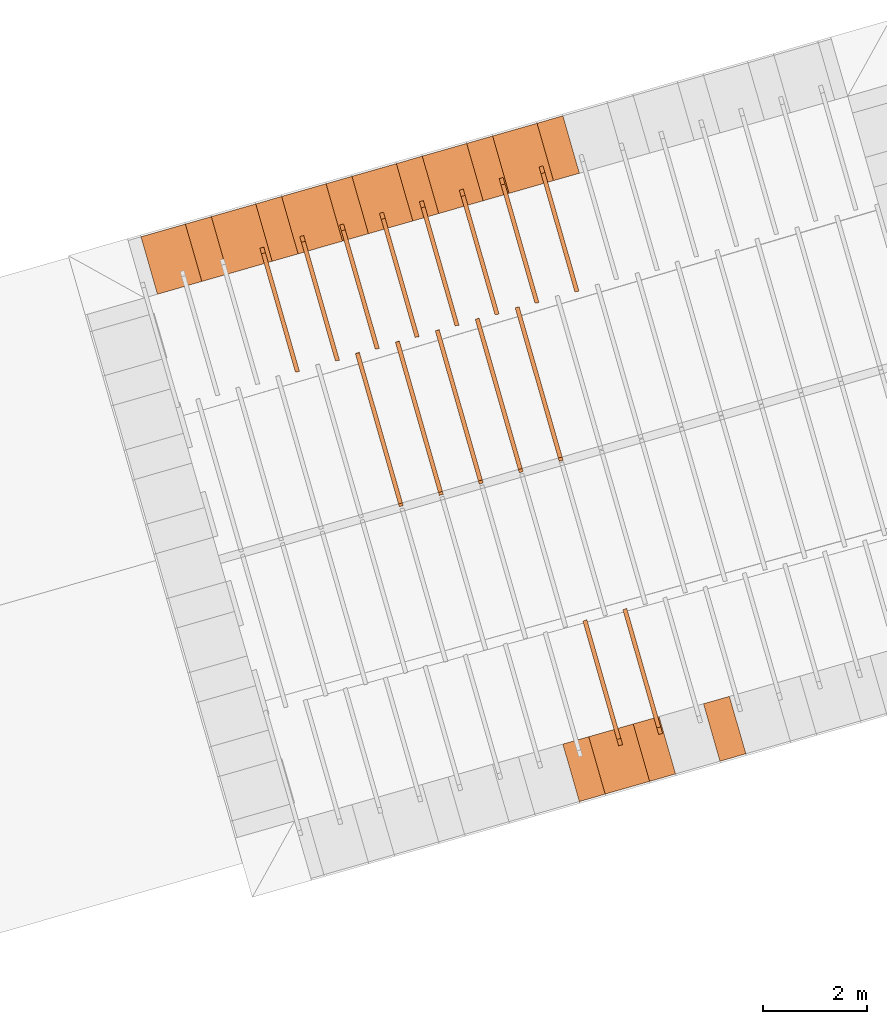
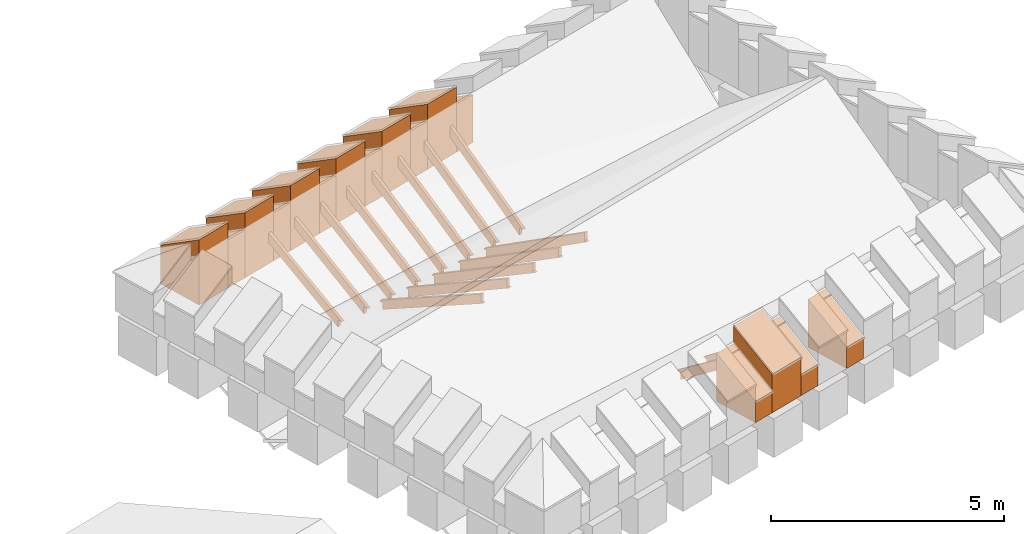
# One storey, part 7 of 10: 31 proxies.
"""IFC4 building model written with IfcOpenShell, lengths in metres."""

import ifcopenshell
import ifcopenshell.guid

model = None  # the IFC model being written
_history = None  # IfcOwnerHistory: only IFC2X3 demands one
_inside = {}  # id of a spatial element -> (the spatial element, [elements in it])
_under = {}  # id of a project, library or spatial element -> (it, [spatial elements below it])
_declared = {}  # id of a project -> (the project, [libraries it declares])
_typed = {}  # id of a type object -> (the type object, [elements of that type])
_made_of = {}  # id of a material, layer set ... -> (it, [elements and type objects made of it])


def new_model(schema):
    """Start an empty IFC model of exactly this schema.

    Asked for "IFC4X3", IfcOpenShell would pick the latest addendum, in which some entities
    have other attributes; the version numbers below select the first issue.
    IFC2X3 requires an IfcOwnerHistory on every rooted entity: one is made here for all.
    """
    global model, _history
    if schema == "IFC4X3":
        model = ifcopenshell.file(schema_version=(4, 3, 0, 0))
    else:
        model = ifcopenshell.file(schema=schema)
    _inside.clear()
    _under.clear()
    _declared.clear()
    _typed.clear()
    _made_of.clear()
    _history = None
    if model.schema == "IFC2X3":
        org = make("IfcOrganization", Name="unknown")
        user = make(
            "IfcPersonAndOrganization",
            ThePerson=make("IfcPerson", FamilyName="unknown"),
            TheOrganization=org,
        )
        app = make(
            "IfcApplication",
            ApplicationDeveloper=org,
            Version="unknown",
            ApplicationFullName="unknown",
            ApplicationIdentifier="unknown",
        )
        _history = make(
            "IfcOwnerHistory",
            OwningUser=user,
            OwningApplication=app,
            ChangeAction="ADDED",
            CreationDate=0,
        )
    return model


def make(cls, **values):
    """One entity of the class cls with the attributes given. An attribute that is None is left unset."""
    return model.create_entity(
        cls, **{name: value for name, value in values.items() if value is not None}
    )


def entity(cls, *values):
    """Any entity or typed value of the class cls, its attributes in the order of the schema. None: left unset."""
    e = model.create_entity(cls)
    for i, value in enumerate(values):
        if value is not None:
            e[i] = value
    return e


def rooted(cls, **values):
    """An entity with a GlobalId (a new one), such as an element, a storey or a relation."""
    return make(cls, GlobalId=ifcopenshell.guid.new(), OwnerHistory=_history, **values)


def si_unit(unit_type, name, prefix=None):
    """IfcSIUnit, for example si_unit("LENGTHUNIT", "METRE", prefix="MILLI")."""
    return make("IfcSIUnit", UnitType=unit_type, Prefix=prefix, Name=name)


def converted_unit(unit_type, name, factor, base, dimensions=None, offset=None):
    """IfcConversionBasedUnit, such as the inch: factor (a typed value) times the base unit."""
    return make(
        "IfcConversionBasedUnit"
        if offset is None
        else "IfcConversionBasedUnitWithOffset",
        ConversionOffset=offset,
        Dimensions=None
        if dimensions is None
        else entity("IfcDimensionalExponents", *dimensions),
        UnitType=unit_type,
        Name=name,
        ConversionFactor=make(
            "IfcMeasureWithUnit", ValueComponent=factor, UnitComponent=base
        ),
    )


def derived_unit(unit_type, elements):
    """IfcDerivedUnit: a product of units, each with its exponent."""
    return make(
        "IfcDerivedUnit",
        Elements=[
            make("IfcDerivedUnitElement", Unit=unit, Exponent=power)
            for unit, power in elements
        ],
        UnitType=unit_type,
    )


def assignment(units):
    """IfcUnitAssignment: the units of a project."""
    return None if units is None else make("IfcUnitAssignment", Units=units)


def point(xyz):
    """IfcCartesianPoint."""
    return None if xyz is None else make("IfcCartesianPoint", Coordinates=xyz)


def direction(xyz):
    """IfcDirection."""
    return None if xyz is None else make("IfcDirection", DirectionRatios=xyz)


def frame(location, z_axis=None, x_axis=None):
    """IfcAxis2Placement3D, a coordinate frame: its origin and axes. An axis left out is left unset."""
    return make(
        "IfcAxis2Placement3D",
        Location=point(location),
        Axis=direction(z_axis),
        RefDirection=direction(x_axis),
    )


def origin_with_axes():
    """The frame at (0, 0, 0) with the z axis (0, 0, 1) and the x axis (1, 0, 0) written out."""
    return frame((0.0, 0.0, 0.0), z_axis=(0.0, 0.0, 1.0), x_axis=(1.0, 0.0, 0.0))


def place(relative_to, where):
    """IfcLocalPlacement: puts the frame where relative to a parent placement (None: the world)."""
    return make(
        "IfcLocalPlacement", PlacementRelTo=relative_to, RelativePlacement=where
    )


def context(
    kind, dimensions, precision=None, world=None, true_north=None, identifier=None
):
    """IfcGeometricRepresentationContext, for example the 3D "Model" context."""
    return make(
        "IfcGeometricRepresentationContext",
        ContextIdentifier=identifier,
        ContextType=kind,
        CoordinateSpaceDimension=dimensions,
        Precision=precision,
        WorldCoordinateSystem=world,
        TrueNorth=true_north,
    )


def subcontext(parent, identifier, kind, view, scale=None):
    """IfcGeometricRepresentationSubContext, for example "Body" below "Model"."""
    return make(
        "IfcGeometricRepresentationSubContext",
        ContextIdentifier=identifier,
        ContextType=kind,
        ParentContext=parent,
        TargetScale=scale,
        TargetView=view,
    )


def project(units=None, contexts=None):
    """IfcProject with its units and contexts."""
    return rooted(
        "IfcProject",
        Name="project",
        RepresentationContexts=contexts,
        UnitsInContext=assignment(units),
    )


def spatial(cls, under=None, at=None, **own):
    """A site, building, storey or space (cls), placed at a placement, below another one or the project."""
    s = rooted(cls, ObjectPlacement=at, **own)
    if under is not None:
        _under.setdefault(under.id(), (under, []))[1].append(s)
    return s


def point_list(points):
    """IfcCartesianPointList2D or 3D."""
    cls = (
        "IfcCartesianPointList2D" if len(points[0]) == 2 else "IfcCartesianPointList3D"
    )
    return make(cls, CoordList=points)


def polygons(points, faces, closed=None, point_numbers=None):
    """IfcPolygonalFaceSet: a face is its outer loop, then its inner loops; points numbered from 1."""
    made = []
    for loops in faces:
        if len(loops) == 1:
            made.append(make("IfcIndexedPolygonalFace", CoordIndex=loops[0]))
        else:
            made.append(
                make(
                    "IfcIndexedPolygonalFaceWithVoids",
                    CoordIndex=loops[0],
                    InnerCoordIndices=loops[1:],
                )
            )
    return make(
        "IfcPolygonalFaceSet",
        Coordinates=point_list(points),
        Closed=closed,
        Faces=made,
        PnIndex=point_numbers,
    )


def shape(context_of_items, identifier, shape_type, items):
    """IfcShapeRepresentation: the items that make up one representation, for example the "Body"."""
    return make(
        "IfcShapeRepresentation",
        ContextOfItems=context_of_items,
        RepresentationIdentifier=identifier,
        RepresentationType=shape_type,
        Items=items,
    )


def material(Name=None, Category=None):
    """IfcMaterial."""
    return make("IfcMaterial", Name=Name, Category=Category)


def made_of(thing, what):
    """Note that an element or type object is made of a material, layer set ...; save() writes the relation."""
    if what is not None:
        _made_of.setdefault(what.id(), (what, []))[1].append(thing)
    return thing


def type_object(cls, material=None, **own):
    """A type object (cls), such as IfcWallType, which elements share."""
    return made_of(rooted(cls, **own), material)


def element(
    cls,
    number,
    at=None,
    inside=None,
    cuts=None,
    type_object=None,
    material=None,
    context=None,
    identifier="Body",
    shape_type=None,
    held_by="IfcProductDefinitionShape",
    body=None,
    shapes=None,
    **own,
):
    """One element of the class cls, such as IfcWall. Its Tag is "e" and its number.

    at: its placement. inside: the storey or other place that contains it. cuts: it is an
    opening in that element (IfcRelVoidsElement). A single representation is given by context,
    identifier, shape_type and body (its items); several are given by shapes. held_by: the class
    of the entity that holds the representations. save() writes the other relations.
    """
    e = rooted(cls, Tag="e%d" % number, ObjectPlacement=at, **own)
    if body is not None:
        shapes = [shape(context, identifier, shape_type, body)]
    if shapes is not None:
        e.Representation = make(held_by, Representations=shapes)
    if inside is not None:
        _inside.setdefault(inside.id(), (inside, []))[1].append(e)
    if cuts is not None:
        rooted(
            "IfcRelVoidsElement", RelatingBuildingElement=cuts, RelatedOpeningElement=e
        )
    if type_object is not None:
        _typed.setdefault(type_object.id(), (type_object, []))[1].append(e)
    return made_of(e, material)


def aggregate(whole, parts):
    """IfcRelAggregates: a whole, such as a stair, and the parts it consists of."""
    return rooted("IfcRelAggregates", RelatingObject=whole, RelatedObjects=parts)


def save(model, path):
    """Write the relations noted so far, then the file.

    IfcRelAggregates (storeys below a building ...), IfcRelContainedInSpatialStructure (elements
    in a storey), IfcRelDefinesByType, IfcRelAssociatesMaterial and IfcRelDeclares: one each for
    every whole, place, type object, material and project.
    """
    for whole, parts in _under.values():
        aggregate(whole, parts)
    for where, things in _inside.values():
        rooted(
            "IfcRelContainedInSpatialStructure",
            RelatedElements=things,
            RelatingStructure=where,
        )
    for kind, things in _typed.values():
        rooted("IfcRelDefinesByType", RelatedObjects=things, RelatingType=kind)
    for what, things in _made_of.values():
        rooted("IfcRelAssociatesMaterial", RelatedObjects=things, RelatingMaterial=what)
    for by, libraries in _declared.values():
        rooted("IfcRelDeclares", RelatingContext=by, RelatedDefinitions=libraries)
    model.write(path)


model = new_model("IFC4")

# Units and contexts
model_context = context("Model", 3, precision=1e-05, world=origin_with_axes(), true_north=direction((0.0, 1.0)))
body_context = subcontext(model_context, "Body", "Model", "MODEL_VIEW")
ifc_project = project(units=[si_unit("LENGTHUNIT", "METRE"), si_unit("AREAUNIT", "SQUARE_METRE"), si_unit("VOLUMEUNIT", "CUBIC_METRE"), converted_unit("PLANEANGLEUNIT", "DEGREE", entity("IfcPlaneAngleMeasure", 0.0174532925199433), si_unit("PLANEANGLEUNIT", "RADIAN"), dimensions=[0, 0, 0, 0, 0, 0, 0]), converted_unit("TIMEUNIT", "Year", entity("IfcTimeMeasure", 31557600.0), si_unit("TIMEUNIT", "SECOND"), dimensions=[0, 0, 1, 0, 0, 0, 0]), si_unit("MASSUNIT", "GRAM", prefix="KILO"), si_unit("THERMODYNAMICTEMPERATUREUNIT", "DEGREE_CELSIUS"), si_unit("LUMINOUSINTENSITYUNIT", "LUMEN"), si_unit("ENERGYUNIT", "JOULE", prefix="MEGA"), derived_unit("THERMALCONDUCTANCEUNIT", [(si_unit("POWERUNIT", "WATT"), 1), (si_unit("LENGTHUNIT", "METRE"), -1), (si_unit("THERMODYNAMICTEMPERATUREUNIT", "KELVIN"), -1)]), derived_unit("SPECIFICHEATCAPACITYUNIT", [(si_unit("ENERGYUNIT", "JOULE"), 1), (si_unit("MASSUNIT", "GRAM", prefix="KILO"), -1), (si_unit("THERMODYNAMICTEMPERATUREUNIT", "KELVIN"), -1)]), derived_unit("MASSDENSITYUNIT", [(si_unit("MASSUNIT", "GRAM", prefix="KILO"), 1), (si_unit("VOLUMEUNIT", "CUBIC_METRE"), -1)])], contexts=[model_context])

# Site, building, storey
site_placement = place(None, frame((0.0, 0.0, 0.0), z_axis=(0.0, 0.0, 1.0), x_axis=(0.9612616959383189, 0.2756373558169991, 0.0)))
site = spatial("IfcSite", under=ifc_project, at=site_placement, CompositionType="ELEMENT")
building_placement = place(site_placement, origin_with_axes())
building = spatial("IfcBuilding", under=site, at=building_placement, CompositionType="ELEMENT")
storey_placement = place(building_placement, frame((0.0, 0.0, 11.0), z_axis=(0.0, 0.0, 1.0), x_axis=(1.0, 0.0, 0.0)))
storey = spatial("IfcBuildingStorey", under=building, at=storey_placement, Name="Dach", CompositionType="ELEMENT", Elevation=11.0)

# Proxies
ifc_material_1 = material()
building_element_proxy_type_1 = type_object("IfcBuildingElementProxyType", PredefinedType="NOTDEFINED")
proxy_1_placement = place(storey_placement, frame((-32.67063236374476, 25.87969375484247, -11.3285), z_axis=(0.0, 0.0, 1.0), x_axis=(-1.0, 0.0, 0.0)))
element("IfcBuildingElementProxy", 1, at=proxy_1_placement, inside=storey, type_object=building_element_proxy_type_1, material=ifc_material_1, Name="008", PredefinedType="NOTDEFINED", context=body_context, shape_type="Tessellation", body=[
    polygons([(-51.43241932296884, 7.415724363527985, 12.2680519937756), (-51.43241932296884, 9.787341089745903, 10.88221930992492), (-51.43241932296884, 9.787341089745903, 11.07227707670844), (-51.43241932296884, 9.898147644674735, 11.07227707670844), (-51.43241932296884, 7.526718754969065, 12.458), (-51.51241932296884, 7.415724363527985, 12.2680519937756), (-51.51241932296884, 9.787341089745903, 10.88221930992492), (-51.51241932296884, 9.787341089745903, 11.06639927890004), (-51.51241932296884, 9.908206495038254, 11.06639927890004), (-51.51241932296884, 7.526718754969065, 12.458)], [[[1, 2, 3, 4, 5]], [[1, 6, 7, 2]], [[2, 7, 8, 3]], [[3, 8, 9, 4]], [[4, 9, 10, 5]], [[5, 10, 6, 1]], [[6, 10, 9, 8, 7]]], closed=True),
])
proxy_2_placement = place(storey_placement, frame((-32.67063236374476, 25.87969375484247, -11.3285), z_axis=(0.0, 0.0, 1.0), x_axis=(-1.0, 0.0, 0.0)))
element("IfcBuildingElementProxy", 2, at=proxy_2_placement, inside=storey, type_object=building_element_proxy_type_1, material=ifc_material_1, Name="008", PredefinedType="NOTDEFINED", context=body_context, shape_type="Tessellation", body=[
    polygons([(-52.23241932296884, 7.412448525633401, 12.27000448226733), (-52.23241932296884, 9.787341089745903, 10.82646199135219), (-52.23241932296884, 9.787341089745903, 11.01349909862444), (-52.23241932296884, 9.90318808034087, 11.01349909862444), (-52.23241932296884, 7.526718754969066, 12.458), (-52.31241932296884, 7.412448525633401, 12.27000448226733), (-52.31241932296884, 9.787341089745903, 10.82646199135219), (-52.31241932296884, 9.787341089745903, 11.00762130081604), (-52.31241932296884, 9.912858137437476, 11.00762130081604), (-52.31241932296884, 7.526718754969066, 12.458)], [[[1, 2, 3, 4, 5]], [[1, 6, 7, 2]], [[2, 7, 8, 3]], [[3, 8, 9, 4]], [[4, 9, 10, 5]], [[5, 10, 6, 1]], [[10, 9, 8, 7, 6]]], closed=True),
])
proxy_3_placement = place(storey_placement, frame((-32.67063236374476, 25.87969375484247, -11.3285), z_axis=(0.0, 0.0, 1.0), x_axis=(-1.0, 0.0, 0.0)))
element("IfcBuildingElementProxy", 3, at=proxy_3_placement, inside=storey, type_object=building_element_proxy_type_1, material=ifc_material_1, Name="008", PredefinedType="NOTDEFINED", context=body_context, shape_type="Tessellation", body=[
    polygons([(-53.03241932296884, 7.408901351535608, 12.27220694456413), (-53.03241932296884, 9.787341089745905, 10.76396115183796), (-53.03241932296884, 9.787341089745903, 10.95472112054043), (-53.03241932296884, 9.89732588131564, 10.95472112054043), (-53.03241932296884, 7.526718754969068, 12.458), (-53.11241932296884, 7.408901351535608, 12.27220694456413), (-53.11241932296884, 9.787341089745905, 10.76396115183796), (-53.11241932296884, 9.787341089745903, 10.94884332273203), (-53.11241932296884, 9.90659491952419, 10.94884332273203), (-53.11241932296884, 7.526718754969068, 12.458)], [[[1, 2, 3, 4, 5]], [[1, 6, 7, 2]], [[2, 7, 8, 3]], [[3, 8, 9, 4]], [[4, 9, 10, 5]], [[5, 10, 6, 1]], [[6, 10, 9, 8, 7]]], closed=True),
])
proxy_4_placement = place(storey_placement, frame((-32.67063236374476, 25.87969375484247, -11.3285), z_axis=(0.0, 0.0, 1.0), x_axis=(-1.0, 0.0, 0.0)))
element("IfcBuildingElementProxy", 4, at=proxy_4_placement, inside=storey, type_object=building_element_proxy_type_1, material=ifc_material_1, Name="008", PredefinedType="NOTDEFINED", context=body_context, shape_type="Tessellation", body=[
    polygons([(-54.63241932296884, 7.402293728881853, 12.27656567887195), (-54.63241932296884, 9.787341089745905, 10.64093478913915), (-54.63241932296884, 9.787341089745903, 10.83716516437243), (-54.63241932296884, 9.890190777523967, 10.83716516437243), (-54.63241932296884, 7.526718754969063, 12.458), (-54.71241932296884, 7.402293728881853, 12.27656567887195), (-54.71241932296884, 9.787341089745905, 10.64093478913915), (-54.71241932296884, 9.787341089745903, 10.83128736656403), (-54.71241932296884, 9.89876167590857, 10.83128736656403), (-54.71241932296884, 7.526718754969063, 12.458)], [[[1, 2, 3, 4, 5]], [[1, 6, 7, 2]], [[2, 7, 8, 3]], [[3, 8, 9, 4]], [[4, 9, 10, 5]], [[5, 10, 6, 1]], [[6, 10, 9, 8, 7]]], closed=True),
])
proxy_5_placement = place(storey_placement, frame((-32.67063236374476, 25.87969375484247, -11.3285), z_axis=(0.0, 0.0, 1.0), x_axis=(-1.0, 0.0, 0.0)))
element("IfcBuildingElementProxy", 5, at=proxy_5_placement, inside=storey, type_object=building_element_proxy_type_1, material=ifc_material_1, Name="008", PredefinedType="NOTDEFINED", context=body_context, shape_type="Tessellation", body=[
    polygons([(-53.83241932296884, 7.405427048607078, 12.27445621239661), (-53.83241932296884, 9.787341089745905, 10.70040991952188), (-53.83241932296884, 9.787341089745903, 10.89594314245643), (-53.83241932296884, 9.890489870775953, 10.89594314245643), (-53.83241932296884, 7.526718754969064, 12.458), (-53.91241932296884, 7.405427048607078, 12.27445621239661), (-53.91241932296884, 9.787341089745905, 10.70040991952187), (-53.91241932296884, 9.787341089745903, 10.89006534464803), (-53.91241932296884, 9.899384405323113, 10.89006534464803), (-53.91241932296884, 7.526718754969064, 12.458)], [[[1, 2, 3, 4, 5]], [[1, 6, 7, 2]], [[2, 7, 8, 3]], [[3, 8, 9, 4]], [[4, 9, 10, 5]], [[5, 10, 6, 1]], [[6, 10, 9, 8, 7]]], closed=True),
])
proxy_6_placement = place(storey_placement, frame((-32.67063236374476, 25.87969375484247, -11.3285), z_axis=(0.0, 0.0, 1.0), x_axis=(-1.0, 0.0, 0.0)))
element("IfcBuildingElementProxy", 6, at=proxy_6_placement, inside=storey, type_object=building_element_proxy_type_1, material=ifc_material_1, Name="008", PredefinedType="NOTDEFINED", context=body_context, shape_type="Tessellation", body=[
    polygons([(-55.43241932296884, 7.399454749157824, 12.27854562467057), (-55.43241932296884, 9.787341089745905, 10.58512365840581), (-55.43241932296884, 9.787341089745905, 10.77838718628843), (-55.43241932296884, 9.895132874566887, 10.77838718628843), (-55.43241932296884, 7.526718754969064, 12.458), (-55.51241932296884, 7.399454749157824, 12.27854562467057), (-55.51241932296884, 9.787341089745905, 10.58512365840581), (-55.51241932296884, 9.787341089745905, 10.77250938848003), (-55.51241932296884, 9.903421129578941, 10.77250938848003), (-55.51241932296884, 7.526718754969064, 12.458)], [[[1, 2, 3, 4, 5]], [[1, 6, 7, 2]], [[2, 7, 8, 3]], [[3, 8, 9, 4]], [[4, 9, 10, 5]], [[5, 10, 6, 1]], [[6, 10, 9, 8, 7]]], closed=True),
])
proxy_7_placement = place(storey_placement, frame((-32.67063236374476, 25.87969375484247, -11.3285), z_axis=(0.0, 0.0, 1.0), x_axis=(-1.0, 0.0, 0.0)))
element("IfcBuildingElementProxy", 7, at=proxy_7_placement, inside=storey, type_object=building_element_proxy_type_1, material=ifc_material_1, Name="008", PredefinedType="NOTDEFINED", context=body_context, shape_type="Tessellation", body=[
    polygons([(-56.23241932296884, 7.39652087048289, 12.28066272000697), (-56.23241932296885, 9.787341089745905, 10.52536493520358), (-56.23241932296885, 9.787341089745905, 10.71960920820443), (-56.23241932296884, 9.894510641900103, 10.71960920820443), (-56.23241932296884, 7.526718754969065, 12.458), (-56.31241932296884, 7.39652087048289, 12.28066272000697), (-56.31241932296885, 9.787341089745905, 10.52536493520359), (-56.31241932296885, 9.787341089745905, 10.71373141039603), (-56.31241932296884, 9.902516552900918, 10.71373141039603), (-56.31241932296884, 7.526718754969065, 12.458)], [[[1, 2, 3, 4, 5]], [[1, 6, 7, 2]], [[2, 7, 8, 3]], [[3, 8, 9, 4]], [[4, 9, 10, 5]], [[5, 10, 6, 1]], [[6, 10, 9, 8, 7]]], closed=True),
])
proxy_8_placement = place(storey_placement, frame((-32.67063236374476, 25.87969375484247, -11.3285), z_axis=(0.0, 0.0, 1.0), x_axis=(-1.0, 0.0, 0.0)))
element("IfcBuildingElementProxy", 8, at=proxy_8_placement, inside=storey, type_object=building_element_proxy_type_1, material=ifc_material_1, Name="008", PredefinedType="NOTDEFINED", context=body_context, shape_type="Tessellation", body=[
    polygons([(-57.03241932296884, 7.393757020753038, 12.28272542330884), (-57.03241932296884, 9.787341089745905, 10.46697384762017), (-57.03241932296884, 9.787341089745905, 10.66083123012043), (-57.03241932296884, 9.895806351791734, 10.66083123012043), (-57.03241932296884, 7.526718754969065, 12.458), (-57.11241932296884, 7.393757020753038, 12.28272542330884), (-57.11241932296884, 9.787341089745905, 10.46697384762017), (-57.11241932296884, 9.787341089745905, 10.65495343231203), (-57.11241932296884, 9.90355466019654, 10.65495343231203), (-57.11241932296884, 7.526718754969065, 12.458)], [[[1, 2, 3, 4, 5]], [[1, 6, 7, 2]], [[2, 7, 8, 3]], [[3, 8, 9, 4]], [[4, 9, 10, 5]], [[5, 10, 6, 1]], [[6, 10, 9, 8, 7]]], closed=True),
])
proxy_9_placement = place(storey_placement, frame((-32.66955969550476, -0.05131726657445945, -11.3285), z_axis=(0.0, 0.0, 1.0), x_axis=(1.0, 0.0, 0.0)))
element("IfcBuildingElementProxy", 9, at=proxy_9_placement, inside=storey, type_object=building_element_proxy_type_1, material=ifc_material_1, Name="008", PredefinedType="NOTDEFINED", context=body_context, shape_type="Tessellation", body=[
    polygons([(55.43241932296884, 7.399454749157824, 12.27854562467057), (55.43241932296884, 7.526718754969064, 12.458), (55.43241932296884, 9.895132874566887, 10.77838718628843), (55.43241932296884, 9.787341089745905, 10.77838718628843), (55.43241932296884, 9.787341089745905, 10.58512365840581), (55.51241932296884, 7.399454749157824, 12.27854562467057), (55.51241932296884, 7.526718754969064, 12.458), (55.51241932296884, 9.903421129578941, 10.77250938848003), (55.51241932296884, 9.787341089745905, 10.77250938848003), (55.51241932296884, 9.787341089745905, 10.58512365840581)], [[[1, 2, 3, 4, 5]], [[2, 1, 6, 7]], [[3, 2, 7, 8]], [[4, 3, 8, 9]], [[5, 4, 9, 10]], [[1, 5, 10, 6]], [[6, 10, 9, 8, 7]]], closed=True),
])
proxy_10_placement = place(storey_placement, frame((-32.66955969550476, -0.05131726657445945, -11.3285), z_axis=(0.0, 0.0, 1.0), x_axis=(1.0, 0.0, 0.0)))
element("IfcBuildingElementProxy", 10, at=proxy_10_placement, inside=storey, type_object=building_element_proxy_type_1, material=ifc_material_1, Name="008", PredefinedType="NOTDEFINED", context=body_context, shape_type="Tessellation", body=[
    polygons([(56.23241932296884, 7.39652087048289, 12.28066272000697), (56.23241932296884, 7.526718754969065, 12.458), (56.23241932296884, 9.894510641900103, 10.71960920820443), (56.23241932296885, 9.787341089745905, 10.71960920820443), (56.23241932296885, 9.787341089745905, 10.52536493520358), (56.31241932296884, 7.39652087048289, 12.28066272000697), (56.31241932296884, 7.526718754969065, 12.458), (56.31241932296884, 9.902516552900918, 10.71373141039603), (56.31241932296885, 9.787341089745905, 10.71373141039603), (56.31241932296885, 9.787341089745905, 10.52536493520359)], [[[1, 2, 3, 4, 5]], [[2, 1, 6, 7]], [[3, 2, 7, 8]], [[4, 3, 8, 9]], [[5, 4, 9, 10]], [[1, 5, 10, 6]], [[6, 10, 9, 8, 7]]], closed=True),
])
proxy_11_placement = place(storey_placement, frame((79.48385070717022, -0.05357057732701342, -11.3285), z_axis=(0.0, 0.0, 1.0), x_axis=(1.0, 0.0, 0.0)))
element("IfcBuildingElementProxy", 11, at=proxy_11_placement, inside=storey, type_object=building_element_proxy_type_1, material=ifc_material_1, Name="003", PredefinedType="NOTDEFINED", context=body_context, shape_type="Tessellation", body=[
    polygons([(-59.43241932244963, 13.04734108974591, 12.42240354413239), (-59.43241932244962, 12.99107606176226, 12.42240354413239), (-59.43241932244962, 15.9873410897459, 10.80736157550196), (-59.43241932244962, 15.9873410897459, 10.97754989230213), (-59.43241932244962, 16.06492572302275, 10.97754989230213), (-59.43241932244962, 16.05704587116538, 11.01971375703324), (-59.43241932244962, 13.04734108974591, 12.642), (-59.51241932244962, 13.04734108974591, 12.42240354413239), (-59.51241932244962, 12.99107606176226, 12.42240354413239), (-59.51241932244962, 15.9873410897459, 10.80736157550196), (-59.51241932244967, 15.9873410897459, 10.98342769011053), (-59.51241932244962, 16.06382724269432, 10.98342769011053), (-59.51241932244962, 16.05704587116538, 11.01971375703324), (-59.51241932244962, 13.04734108974591, 12.642)], [[[1, 2, 3, 4, 5, 6, 7]], [[1, 8, 9, 2]], [[3, 2, 9, 10]], [[3, 10, 11, 4]], [[4, 11, 12, 5]], [[5, 12, 13, 6]], [[6, 13, 14, 7]], [[7, 14, 8, 1]], [[13, 12, 11, 10, 9, 8, 14]]], closed=True),
])
proxy_12_placement = place(storey_placement, frame((79.48385070717022, -0.05357057732701342, -11.3285), z_axis=(0.0, 0.0, 1.0), x_axis=(1.0, 0.0, 0.0)))
element("IfcBuildingElementProxy", 12, at=proxy_12_placement, inside=storey, type_object=building_element_proxy_type_1, material=ifc_material_1, Name="003", PredefinedType="NOTDEFINED", context=body_context, shape_type="Tessellation", body=[
    polygons([(-58.63241932244962, 13.04734108974591, 12.42240354413239), (-58.63241932244962, 12.98891040279966, 12.42240354413239), (-58.63241932244962, 15.9873410897459, 10.73292267693545), (-58.63241932244962, 15.9873410897459, 10.91877191421813), (-58.63241932244962, 16.06163601740884, 10.91877191421813), (-58.63241932244962, 16.05704587116536, 10.94616668750873), (-58.63241932244962, 13.04734108974591, 12.642), (-58.71241932244962, 13.04734108974591, 12.42240354413239), (-58.71241932244962, 12.98891040279966, 12.42240354413239), (-58.71241932244962, 15.9873410897459, 10.73292267693545), (-58.71241932244962, 15.9873410897459, 10.92464971202653), (-58.71241932244962, 16.06065115977765, 10.92464971202653), (-58.71241932244962, 16.05704587116536, 10.94616668750873), (-58.71241932244962, 13.04734108974591, 12.642)], [[[1, 2, 3, 4, 5, 6, 7]], [[1, 8, 9, 2]], [[3, 2, 9, 10]], [[3, 10, 11, 4]], [[4, 11, 12, 5]], [[5, 12, 13, 6]], [[6, 13, 14, 7]], [[7, 14, 8, 1]], [[13, 12, 11, 10, 9, 8, 14]]], closed=True),
])
proxy_13_placement = place(storey_placement, frame((79.48385070717022, -0.05357057732701342, -11.3285), z_axis=(0.0, 0.0, 1.0), x_axis=(1.0, 0.0, 0.0)))
element("IfcBuildingElementProxy", 13, at=proxy_13_placement, inside=storey, type_object=building_element_proxy_type_1, material=ifc_material_1, Name="003", PredefinedType="NOTDEFINED", context=body_context, shape_type="Tessellation", body=[
    polygons([(-57.83241932244969, 13.04734108974591, 12.42240354413239), (-57.83241932244962, 12.98715692842933, 12.42240354413239), (-57.83241932244962, 15.9873410897459, 10.6717587829879), (-57.83241932244962, 15.9873410897459, 10.85999393613413), (-57.83241932244962, 16.06097033880345, 10.85999393613413), (-57.83241932244962, 16.05704587116535, 10.88579983865006), (-57.83241932244962, 13.04734108974591, 12.642), (-57.91241932244962, 13.04734108974591, 12.42240354413239), (-57.91241932244962, 12.98715692842933, 12.42240354413239), (-57.91241932244962, 15.9873410897459, 10.6717587829879), (-57.91241932244965, 15.9873410897459, 10.86587173394253), (-57.91241932244962, 16.06007646472684, 10.86587173394253), (-57.91241932244962, 16.05704587116535, 10.88579983865006), (-57.91241932244962, 13.04734108974591, 12.642)], [[[1, 2, 3, 4, 5, 6, 7]], [[1, 8, 9, 2]], [[3, 2, 9, 10]], [[3, 10, 11, 4]], [[4, 11, 12, 5]], [[5, 12, 13, 6]], [[6, 13, 14, 7]], [[7, 14, 8, 1]], [[13, 12, 11, 10, 9, 8, 14]]], closed=True),
])
proxy_14_placement = place(storey_placement, frame((79.48385070717022, -0.05357057732701342, -11.3285), z_axis=(0.0, 0.0, 1.0), x_axis=(1.0, 0.0, 0.0)))
element("IfcBuildingElementProxy", 14, at=proxy_14_placement, inside=storey, type_object=building_element_proxy_type_1, material=ifc_material_1, Name="003", PredefinedType="NOTDEFINED", context=body_context, shape_type="Tessellation", body=[
    polygons([(-57.03241932244966, 13.0473410897459, 12.42240354413239), (-57.03241932244962, 12.9853757512264, 12.42240354413239), (-57.03241932244962, 15.9873410897459, 10.60876590451085), (-57.03241932244963, 15.9873410897459, 10.80121595805013), (-57.03241932244962, 16.06011313379123, 10.80121595805013), (-57.03241932244962, 16.05704587116533, 10.8236865752276), (-57.03241932244962, 13.04734108974591, 12.642), (-57.11241932244962, 13.0473410897459, 12.42240354413239), (-57.11241932244962, 12.9853757512264, 12.42240354413239), (-57.11241932244962, 15.9873410897459, 10.60876590451085), (-57.11241932244967, 15.9873410897459, 10.80709375585853), (-57.11241932244962, 16.0593108082744, 10.80709375585853), (-57.11241932244962, 16.05704587116533, 10.8236865752276), (-57.11241932244962, 13.04734108974591, 12.642)], [[[1, 2, 3, 4, 5, 6, 7]], [[1, 8, 9, 2]], [[3, 2, 9, 10]], [[3, 10, 11, 4]], [[4, 11, 12, 5]], [[5, 12, 13, 6]], [[6, 13, 14, 7]], [[7, 14, 8, 1]], [[13, 12, 11, 10, 9, 8, 14]]], closed=True),
])
proxy_15_placement = place(storey_placement, frame((79.48385070717022, -0.05357057732701342, -11.3285), z_axis=(0.0, 0.0, 1.0), x_axis=(1.0, 0.0, 0.0)))
element("IfcBuildingElementProxy", 15, at=proxy_15_placement, inside=storey, type_object=building_element_proxy_type_1, material=ifc_material_1, Name="003", PredefinedType="NOTDEFINED", context=body_context, shape_type="Tessellation", body=[
    polygons([(-56.23241932244962, 13.0473410897459, 12.42240354413239), (-56.23241932244962, 12.98364967905431, 12.42240354413239), (-56.23241932244962, 15.9873410897459, 10.54685159078951), (-56.23241932244962, 15.9873410897459, 10.74243797996612), (-56.23241932244962, 16.05950773769253, 10.74243797996612), (-56.23241932244962, 16.05704587116531, 10.7626932038078), (-56.23241932244962, 13.0473410897459, 12.642), (-56.31241932244962, 13.0473410897459, 12.42240354413239), (-56.31241932244962, 12.98364967905431, 12.42240354413239), (-56.31241932244962, 15.9873410897459, 10.54685159078951), (-56.31241932244962, 15.9873410897459, 10.74831577777453), (-56.31241932244962, 16.05879333661796, 10.74831577777453), (-56.31241932244962, 16.05704587116531, 10.7626932038078), (-56.31241932244962, 13.0473410897459, 12.642)], [[[1, 2, 3, 4, 5, 6, 7]], [[1, 8, 9, 2]], [[3, 2, 9, 10]], [[3, 10, 11, 4]], [[4, 11, 12, 5]], [[5, 12, 13, 6]], [[6, 13, 14, 7]], [[7, 14, 8, 1]], [[13, 12, 11, 10, 9, 8, 14]]], closed=True),
])
ifc_material_2 = material()
building_element_proxy_type_2 = type_object("IfcBuildingElementProxyType", Name="519 x 1150", PredefinedType="NOTDEFINED")
proxy_16_placement = place(storey_placement, frame((17.77129984279965, 18.73164613654701, 0.2019994076779703), z_axis=(0.0, 0.0, 1.0), x_axis=(-1.0, -4.799646136429001e-09, 0.0)))
element("IfcBuildingElementProxy", 16, at=proxy_16_placement, inside=storey, type_object=building_element_proxy_type_2, material=ifc_material_2, PredefinedType="NOTDEFINED", context=body_context, shape_type="Tessellation", body=[
    polygons([(0.2594814554022662, 0.5749999999999993, 1.258340042868717), (0.2594814554022662, 0.5749999999999993, 0.0), (-0.2594814554022662, 0.5749999999999993, 0.0), (-0.2594814554022662, 0.5749999999999993, 1.258340042868717), (0.2594814554022697, -0.5750000000000028, 0.5616599571312832), (0.2594814554022697, -0.5750000000000028, 0.0), (-0.2594814554022626, -0.5750000000000028, 0.0), (-0.2594814554022626, -0.5750000000000028, 0.5616599571312832)], [[[1, 2, 3, 4]], [[5, 6, 2, 1]], [[3, 2, 6, 7]], [[4, 3, 7, 8]], [[5, 1, 4, 8]], [[8, 7, 6, 5]]], closed=True),
])
proxy_17_placement = place(storey_placement, frame((19.18025924177032, 18.73164613983133, 0.2019994076779703), z_axis=(0.0, 0.0, 1.0), x_axis=(-1.0, -4.799646136429001e-09, 0.0)))
element("IfcBuildingElementProxy", 17, at=proxy_17_placement, inside=storey, type_object=building_element_proxy_type_2, material=ifc_material_2, PredefinedType="NOTDEFINED", context=body_context, shape_type="Tessellation", body=[
    polygons([(0.2594846541917271, 0.5749999999999993, 1.258340042868717), (0.2594846541917271, 0.5749999999999993, 0.0), (-0.2594846541917235, 0.5750000000000028, 0.0), (-0.2594846541917235, 0.5750000000000028, 1.258340042868717), (0.2594846541917271, -0.5750000000000028, 0.5616599571312832), (0.2594846541917271, -0.5750000000000028, 0.0), (-0.2594846541917235, -0.5749999999999993, 0.0), (-0.2594846541917235, -0.5749999999999993, 0.5616599571312832)], [[[1, 2, 3, 4]], [[5, 6, 2, 1]], [[3, 2, 6, 7]], [[4, 3, 7, 8]], [[5, 1, 4, 8]], [[8, 7, 6, 5]]], closed=True),
])
proxy_18_placement = place(storey_placement, frame((21.99818491005598, 18.73164614640001, 0.2019994076779703), z_axis=(0.0, 0.0, 1.0), x_axis=(-1.0, -4.799646136429001e-09, 0.0)))
element("IfcBuildingElementProxy", 18, at=proxy_18_placement, inside=storey, type_object=building_element_proxy_type_2, material=ifc_material_2, PredefinedType="NOTDEFINED", context=body_context, shape_type="Tessellation", body=[
    polygons([(0.259479377542867, 0.5750000000000028, 1.258340042868717), (0.259479377542867, 0.5750000000000028, 0.0), (-0.2594793775428634, 0.5750000000000028, 0.0), (-0.2594793775428634, 0.5750000000000028, 1.258340042868717), (0.259479377542867, -0.5749999999999993, 0.5616599571312832), (0.259479377542867, -0.5749999999999993, 0.0), (-0.2594793775428634, -0.5749999999999993, 0.0), (-0.2594793775428634, -0.5749999999999993, 0.5616599571312832)], [[[1, 2, 3, 4]], [[5, 6, 2, 1]], [[3, 2, 6, 7]], [[4, 3, 7, 8]], [[5, 1, 4, 8]], [[8, 7, 6, 5]]], closed=True),
])
proxy_19_placement = place(storey_placement, frame((20.58922398959632, 18.73164614311568, 0.2019994076779703), z_axis=(0.0, 0.0, 1.0), x_axis=(-1.0, -4.799646136429001e-09, 0.0)))
element("IfcBuildingElementProxy", 19, at=proxy_19_placement, inside=storey, type_object=building_element_proxy_type_2, material=ifc_material_2, PredefinedType="NOTDEFINED", context=body_context, shape_type="Tessellation", body=[
    polygons([(0.2594796273897408, 0.5749999999999993, 1.258340042868717), (0.2594796273897408, 0.5749999999999993, 0.0), (-0.2594796273897373, 0.5749999999999993, 0.0), (-0.2594796273897373, 0.5749999999999993, 1.258340042868717), (0.2594796273897408, -0.5749999999999993, 0.5616599571312832), (0.2594796273897408, -0.5749999999999993, 0.0), (-0.2594796273897373, -0.5749999999999993, 0.0), (-0.2594796273897373, -0.5749999999999993, 0.5616599571312832)], [[[1, 2, 3, 4]], [[5, 6, 2, 1]], [[3, 2, 6, 7]], [[4, 3, 7, 8]], [[5, 1, 4, 8]], [[8, 7, 6, 5]]], closed=True),
])
proxy_20_placement = place(storey_placement, frame((23.40714550617917, 18.73164614968434, 0.2019994076779703), z_axis=(0.0, 0.0, 1.0), x_axis=(-1.0, -4.799646136429001e-09, 0.0)))
element("IfcBuildingElementProxy", 20, at=proxy_20_placement, inside=storey, type_object=building_element_proxy_type_2, material=ifc_material_2, PredefinedType="NOTDEFINED", context=body_context, shape_type="Tessellation", body=[
    polygons([(0.2594791373788148, 0.5749999999999993, 1.258340042868717), (0.2594791373788148, 0.5749999999999993, 0.0), (-0.2594791373788112, 0.5749999999999993, 0.0), (-0.2594791373788112, 0.5749999999999993, 1.258340042868717), (0.2594791373788148, -0.5749999999999993, 0.5616599571312832), (0.2594791373788148, -0.5749999999999993, 0.0), (-0.2594791373788112, -0.5749999999999993, 0.0), (-0.2594791373788112, -0.5749999999999993, 0.5616599571312832)], [[[1, 2, 3, 4]], [[5, 6, 2, 1]], [[3, 2, 6, 7]], [[4, 3, 7, 8]], [[5, 1, 4, 8]], [[8, 7, 6, 5]]], closed=True),
])
proxy_21_placement = place(storey_placement, frame((24.81610634207828, 18.73164615296866, 0.2019994076779703), z_axis=(0.0, 0.0, 1.0), x_axis=(-1.0, -4.799646136429001e-09, 0.0)))
element("IfcBuildingElementProxy", 21, at=proxy_21_placement, inside=storey, type_object=building_element_proxy_type_2, material=ifc_material_2, PredefinedType="NOTDEFINED", context=body_context, shape_type="Tessellation", body=[
    polygons([(0.2594791378341235, 0.5749999999999993, 1.258340042868717), (0.2594791378341235, 0.5749999999999993, 0.0), (-0.2594791378341235, 0.5750000000000028, 0.0), (-0.2594791378341235, 0.5750000000000028, 1.258340042868717), (0.259479137834127, -0.5749999999999993, 0.5616599571312832), (0.259479137834127, -0.5749999999999993, 0.0), (-0.2594791378341199, -0.5749999999999957, 0.0), (-0.2594791378341199, -0.5749999999999957, 0.5616599571312832)], [[[1, 2, 3, 4]], [[5, 6, 2, 1]], [[3, 2, 6, 7]], [[4, 3, 7, 8]], [[5, 1, 4, 8]], [[8, 7, 6, 5]]], closed=True),
])
proxy_22_placement = place(storey_placement, frame((21.99818490729619, 7.100401470013415, 0.2019994076779703), z_axis=(0.0, 0.0, 1.0), x_axis=(1.0, 0.0, 0.0)))
element("IfcBuildingElementProxy", 22, at=proxy_22_placement, inside=storey, type_object=building_element_proxy_type_2, material=ifc_material_2, PredefinedType="NOTDEFINED", context=body_context, shape_type="Tessellation", body=[
    polygons([(-0.2594793775428634, -0.5750000000000002, 0.5616599571312832), (-0.2594793775428634, -0.5750000000000002, 0.0), (0.259479377542867, -0.5750000000000002, 0.0), (0.259479377542867, -0.5750000000000002, 0.5616599571312832), (-0.2594793775428634, 0.5750000000000002, 1.258340042868717), (-0.2594793775428634, 0.5750000000000002, 0.0), (0.259479377542867, 0.5750000000000002, 0.0), (0.259479377542867, 0.5750000000000002, 1.258340042868717)], [[[1, 2, 3, 4]], [[5, 6, 2, 1]], [[3, 2, 6, 7]], [[4, 3, 7, 8]], [[5, 1, 4, 8]], [[8, 7, 6, 5]]], closed=True),
])
proxy_23_placement = place(storey_placement, frame((23.40714550341939, 7.100401473491607, 0.2019994076779703), z_axis=(0.0, 0.0, 1.0), x_axis=(1.0, 0.0, 0.0)))
element("IfcBuildingElementProxy", 23, at=proxy_23_placement, inside=storey, type_object=building_element_proxy_type_2, material=ifc_material_2, PredefinedType="NOTDEFINED", context=body_context, shape_type="Tessellation", body=[
    polygons([(-0.2594791373788112, -0.5750000000000002, 0.5616599571312832), (-0.2594791373788112, -0.5750000000000002, 0.0), (0.2594791373788148, -0.5750000000000002, 0.0), (0.2594791373788148, -0.5750000000000002, 0.5616599571312832), (-0.2594791373788112, 0.5750000000000002, 1.258340042868717), (-0.2594791373788112, 0.5750000000000002, 0.0), (0.2594791373788148, 0.5750000000000002, 0.0), (0.2594791373788148, 0.5750000000000002, 1.258340042868717)], [[[1, 2, 3, 4]], [[5, 6, 2, 1]], [[3, 2, 6, 7]], [[4, 3, 7, 8]], [[5, 1, 4, 8]], [[8, 7, 6, 5]]], closed=True),
])
proxy_24_placement = place(storey_placement, frame((24.81610633931849, 7.100401476969799, 0.2019994076779703), z_axis=(0.0, 0.0, 1.0), x_axis=(1.0, 0.0, 0.0)))
element("IfcBuildingElementProxy", 24, at=proxy_24_placement, inside=storey, type_object=building_element_proxy_type_2, material=ifc_material_2, PredefinedType="NOTDEFINED", context=body_context, shape_type="Tessellation", body=[
    polygons([(-0.2594791378341199, -0.5750000000000002, 0.5616599571312832), (-0.2594791378341199, -0.5750000000000002, 0.0), (0.259479137834127, -0.5750000000000002, 0.0), (0.259479137834127, -0.5750000000000002, 0.5616599571312832), (-0.2594791378341235, 0.5750000000000002, 1.258340042868717), (-0.2594791378341235, 0.5750000000000002, 0.0), (0.2594791378341235, 0.5750000000000002, 0.0), (0.2594791378341235, 0.5750000000000002, 1.258340042868717)], [[[1, 2, 3, 4]], [[5, 6, 2, 1]], [[3, 2, 6, 7]], [[4, 3, 7, 8]], [[5, 1, 4, 8]], [[8, 7, 6, 5]]], closed=True),
])
building_element_proxy_type_3 = type_object("IfcBuildingElementProxyType", Name="890 x 1150", PredefinedType="NOTDEFINED")
proxy_25_placement = place(storey_placement, frame((24.11162592402074, 18.73164615062952, 0.2019994076779703), z_axis=(0.0, 0.0, 1.0), x_axis=(-1.0, -4.202208037436403e-09, 0.0)))
element("IfcBuildingElementProxy", 25, at=proxy_25_placement, inside=storey, type_object=building_element_proxy_type_3, material=ifc_material_2, PredefinedType="NOTDEFINED", context=body_context, shape_type="Tessellation", body=[
    polygons([(0.4450012808476238, 0.5749999999999993, 1.70834004286872), (0.4450012808476238, 0.5749999999999993, 0.0), (-0.4450012808476274, 0.5749999999999993, 0.0), (-0.4450012808476274, 0.5749999999999993, 1.70834004286872), (0.4450012808476238, -0.5749999999999993, 1.011659957131286), (0.4450012808476238, -0.5749999999999993, 0.0), (-0.4450012808476274, -0.5749999999999993, 0.0), (-0.4450012808476274, -0.5749999999999993, 1.011659957131286)], [[[1, 2, 3, 4]], [[5, 6, 2, 1]], [[3, 2, 6, 7]], [[4, 3, 7, 8]], [[5, 1, 4, 8]], [[8, 7, 6, 5]]], closed=True),
])
for number, where, z_axis, x_axis in (
    (26, (22.70266508768812, 18.73164614783915, 0.2019994076779703), (0.0, 0.0, 1.0), (-1.0, -4.202208037436403e-09, 0.0)),
    (27, (21.29370425135549, 18.73164614504878, 0.2019994076779703), (0.0, 0.0, 1.0), (-1.0, -4.202208037436403e-09, 0.0)),
):
    element("IfcBuildingElementProxy", number, at=place(storey_placement, frame(where, z_axis=z_axis, x_axis=x_axis)), inside=storey, type_object=building_element_proxy_type_3, material=ifc_material_2, PredefinedType="NOTDEFINED", context=body_context, shape_type="Tessellation", body=[
        polygons([(0.4450012808476238, 0.5749999999999993, 1.708340042868716), (0.4450012808476238, 0.5749999999999993, 0.0), (-0.4450012808476274, 0.5749999999999993, 0.0), (-0.4450012808476274, 0.5749999999999993, 1.708340042868716), (0.4450012808476238, -0.5749999999999993, 1.011659957131281), (0.4450012808476238, -0.5749999999999993, 0.0), (-0.4450012808476274, -0.5749999999999993, 0.0), (-0.4450012808476274, -0.5749999999999993, 1.011659957131281)], [[[1, 2, 3, 4]], [[5, 6, 2, 1]], [[3, 2, 6, 7]], [[4, 3, 7, 8]], [[5, 1, 4, 8]], [[8, 7, 6, 5]]], closed=True),
    ])
for number, where, z_axis, x_axis in (
    (28, (19.88474341502288, 18.7316461422584, 0.2019994076779703), (0.0, 0.0, 1.0), (-1.0, -4.202208037436403e-09, 0.0)),
    (29, (18.47578257869025, 18.73164613946803, 0.2019994076779703), (0.0, 0.0, 1.0), (-1.0, -4.202208037436403e-09, 0.0)),
    (30, (17.06682174235763, 18.73164613667765, 0.2019994076779703), (0.0, 0.0, 1.0), (-1.0, -4.202208037436403e-09, 0.0)),
):
    element("IfcBuildingElementProxy", number, at=place(storey_placement, frame(where, z_axis=z_axis, x_axis=x_axis)), inside=storey, type_object=building_element_proxy_type_3, material=ifc_material_2, PredefinedType="NOTDEFINED", context=body_context, shape_type="Tessellation", body=[
        polygons([(0.4450012808476238, 0.5749999999999993, 1.70834004286872), (0.4450012808476238, 0.5749999999999993, 0.0), (-0.4450012808476274, 0.5749999999999993, 0.0), (-0.4450012808476274, 0.5749999999999993, 1.70834004286872), (0.4450012808476238, -0.5749999999999993, 1.011659957131286), (0.4450012808476238, -0.5749999999999993, 0.0), (-0.4450012808476274, -0.5749999999999993, 0.0), (-0.4450012808476274, -0.5749999999999993, 1.011659957131286)], [[[1, 2, 3, 4]], [[5, 6, 2, 1]], [[3, 2, 6, 7]], [[4, 3, 7, 8]], [[5, 1, 4, 8]], [[8, 7, 6, 5]]], closed=True),
    ])
proxy_26_placement = place(storey_placement, frame((22.70266508527185, 7.100401471752511, 0.2019994076779703), z_axis=(0.0, 0.0, 1.0), x_axis=(1.0, 0.0, 0.0)))
element("IfcBuildingElementProxy", 31, at=proxy_26_placement, inside=storey, type_object=building_element_proxy_type_3, material=ifc_material_2, PredefinedType="NOTDEFINED", context=body_context, shape_type="Tessellation", body=[
    polygons([(-0.4450012808476238, -0.5749999999999993, 1.011659957131284), (-0.4450012808476238, -0.5749999999999993, 0.0), (0.4450012808476238, -0.5750000000000002, 0.0), (0.4450012808476238, -0.5750000000000002, 1.011659957131284), (-0.4450012808476238, 0.5750000000000002, 1.708340042868718), (-0.4450012808476238, 0.5750000000000002, 0.0), (0.4450012808476238, 0.5749999999999993, 0.0), (0.4450012808476238, 0.5749999999999993, 1.708340042868718)], [[[1, 2, 3, 4]], [[5, 6, 2, 1]], [[3, 2, 6, 7]], [[4, 3, 7, 8]], [[5, 1, 4, 8]], [[8, 7, 6, 5]]], closed=True),
])

save(model, "model.ifc")
